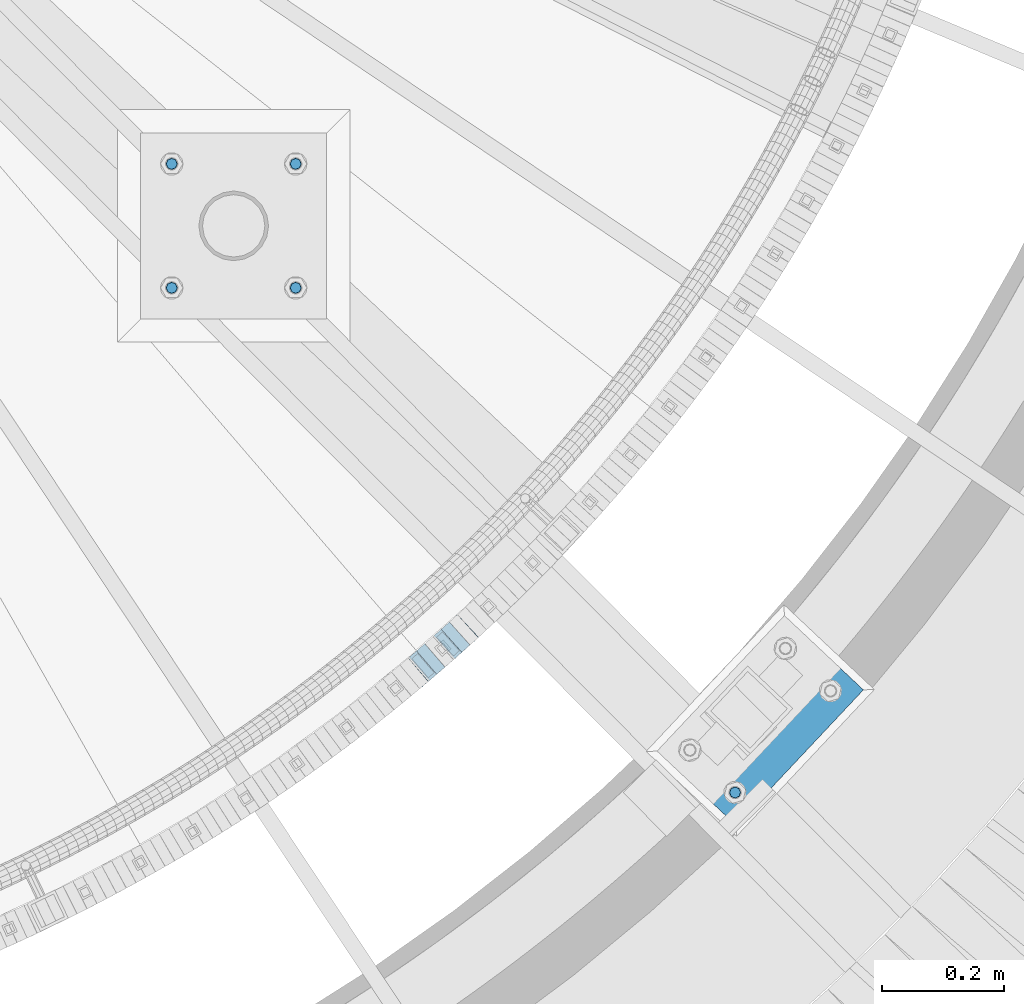
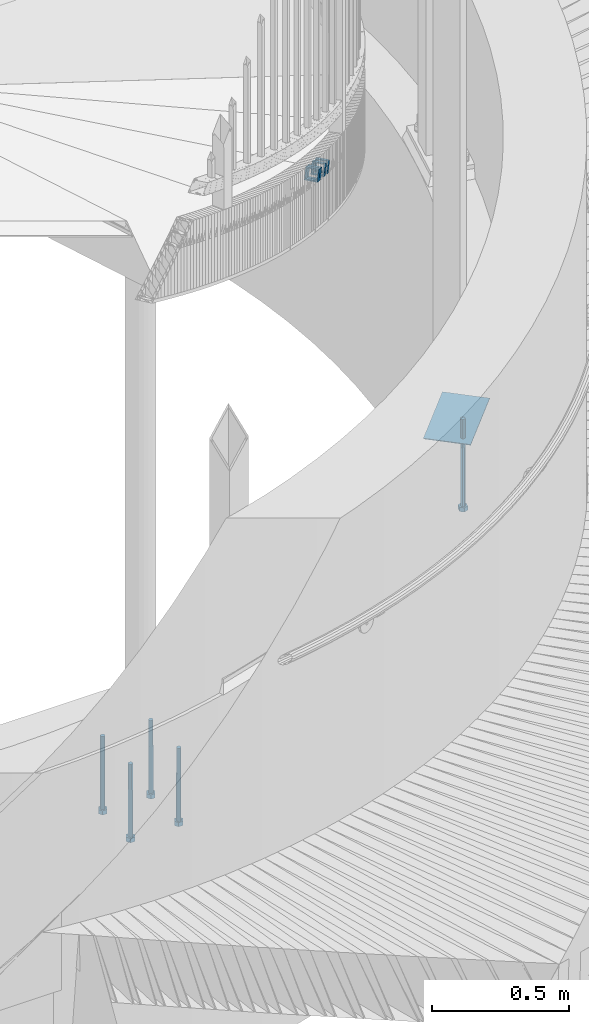
# One storey, part 491 of 975: 10 beams.
"""IFC2X3 building model written with IfcOpenShell, lengths in millimetres."""

from ifc_helpers import new_model, si_unit, frame, origin_with_axes, place, context, subcontext, project, spatial, faceted_brep, material, type_object, element, save


model = new_model("IFC2X3")

# Units and contexts
model_context = context("Model", 3, precision=1e-05, world=origin_with_axes())
body_context = subcontext(model_context, "Body", "Model", "MODEL_VIEW")
ifc_project = project(units=[si_unit("LENGTHUNIT", "METRE", prefix="MILLI"), si_unit("AREAUNIT", "SQUARE_METRE"), si_unit("VOLUMEUNIT", "CUBIC_METRE"), si_unit("MASSUNIT", "GRAM", prefix="KILO"), si_unit("TIMEUNIT", "SECOND"), si_unit("PLANEANGLEUNIT", "RADIAN"), si_unit("SOLIDANGLEUNIT", "STERADIAN"), si_unit("THERMODYNAMICTEMPERATUREUNIT", "DEGREE_CELSIUS"), si_unit("LUMINOUSINTENSITYUNIT", "LUMEN")], contexts=[model_context])

# Site, building, storey
site_placement = place(None, origin_with_axes())
site = spatial("IfcSite", under=ifc_project, at=site_placement, CompositionType="ELEMENT")
building_placement = place(site_placement, origin_with_axes())
building = spatial("IfcBuilding", under=site, at=building_placement, Name="Undefined", CompositionType="ELEMENT")
storey_placement = place(building_placement, origin_with_axes())
storey = spatial("IfcBuildingStorey", under=building, at=storey_placement, Name="Undefined", CompositionType="ELEMENT", Elevation=0.0)

# Beams
ifc_material_1 = material()
beam_type_1 = type_object("IfcBeamType", Name="HSS2X2X.188_TUBES", PredefinedType="NOTDEFINED")
for number, where, z_axis, x_axis, name in (
    (1, (36586.3070314841, 1210.1230873625, 2648.6316623909), (-0.652167428575804, 0.758074960082988, -1.21461653179722e-10), (0.721315416246313, 0.620543409211908, -0.307619810105057), "WALL"),
    (2, (36599.9070314841, 1221.82308736249, 2642.8316623909), (-0.652167428575804, 0.758074960082988, -1.21461653179722e-10), (0.721315416246313, 0.620543409211908, -0.307619810105057), "WALL"),
):
    element("IfcBeam", number, at=place(storey_placement, frame(where, z_axis=z_axis, x_axis=x_axis)), inside=storey, type_object=beam_type_1, material=ifc_material_1, Name=name, ObjectType="HSS2X2X.188_TUBES", context=body_context, shape_type="Brep", body=[
        faceted_brep([(0.0, 20.6374999999753, -20.6375000000298), (0.0, -20.6375000000153, -20.6375000000153), (18.8480768248774, -20.6374999999716, -20.6375000000735), (18.8480768249356, 20.6375000000153, -20.6375000000226), (0.0, -20.6374999999825, 20.6375000000335), (18.8480768249283, -20.6374999999935, 20.6374999999716), (0.0, 20.6375000000116, 20.6375000000189), (18.8480768249865, 20.6374999999935, 20.6375000000262), (0.0, 25.3999999999724, -25.4000000000342), (0.0, 25.400000000016, 25.4000000000196), (18.848076825001, 25.3999999999887, 25.4000000000378), (18.8480768249392, 25.4000000000142, -25.4000000000233), (0.0, -25.399999999976, 25.4000000000378), (18.8480768249283, -25.399999999996, 25.3999999999833), (0.0, -25.400000000016, -25.4000000000196), (18.8480768248664, -25.3999999999687, -25.4000000000779)], [[[0, 1, 2, 3]], [[1, 4, 5, 2]], [[4, 6, 7, 5]], [[6, 0, 3, 7]], [[8, 9, 10, 11]], [[9, 12, 13, 10]], [[12, 14, 15, 13]], [[14, 8, 11, 15]], [[13, 15, 11, 10], [5, 7, 3, 2]], [[14, 12, 9, 8], [6, 4, 1, 0]]]),
    ])
beam_1_placement = place(storey_placement, frame((36640.8512122932, 1257.4100463893, 2625.64368106898), z_axis=(-0.666794859366766, 0.74524131361731, 1.71758983924519e-10), x_axis=(0.708751451080152, 0.634146035071732, -0.309079580034951)))
element("IfcBeam", 3, at=beam_1_placement, inside=storey, type_object=beam_type_1, material=ifc_material_1, Name="WALL", ObjectType="HSS2X2X.188_TUBES", context=body_context, shape_type="Brep", body=[
    faceted_brep([(0.0, 20.6374999999753, -20.6375000000298), (0.0, -20.6375000000153, -20.6375000000153), (18.767258723612, -20.6375000000025, -20.6374999999862), (18.7672587236229, 20.6374999999953, -20.637499999968), (0.0, -20.6374999999825, 20.6375000000335), (18.767258723612, -20.6375000000135, 20.6375000000153), (0.0, 20.6375000000116, 20.6375000000189), (18.7672587236266, 20.6374999999844, 20.6375000000371), (0.0, 25.3999999999724, -25.4000000000342), (0.0, 25.400000000016, 25.4000000000196), (18.7672587236302, 25.3999999999814, 25.4000000000342), (18.7672587236229, 25.399999999996, -25.3999999999687), (0.0, -25.399999999976, 25.4000000000378), (18.7672587236157, -25.4000000000142, 25.400000000016), (0.0, -25.400000000016, -25.4000000000196), (18.767258723612, -25.4000000000015, -25.3999999999905)], [[[0, 1, 2, 3]], [[1, 4, 5, 2]], [[4, 6, 7, 5]], [[6, 0, 3, 7]], [[8, 9, 10, 11]], [[9, 12, 13, 10]], [[12, 14, 15, 13]], [[14, 8, 11, 15]], [[13, 15, 11, 10], [5, 7, 3, 2]], [[14, 12, 9, 8], [6, 4, 1, 0]]]),
])
beam_2_placement = place(storey_placement, frame((36667.8285496277, 1281.58500124165, 2614.14542239957), z_axis=(-0.678512970064767, 0.734588421807674, 5.79152583668474e-11), x_axis=(0.698569804897863, 0.645243865905667, -0.309290447954784)))
element("IfcBeam", 4, at=beam_2_placement, inside=storey, type_object=beam_type_1, material=ifc_material_1, Name="WALL", ObjectType="HSS2X2X.188_TUBES", context=body_context, shape_type="Brep", body=[
    faceted_brep([(0.0, 20.6374999999753, -20.6375000000298), (0.0, -20.6375000000153, -20.6375000000153), (18.7547327359644, -20.6374999999844, -20.6375000000553), (18.7547327359898, 20.6375000000171, -20.6375000000335), (0.0, -20.6374999999825, 20.6375000000335), (18.7547327360044, -20.6374999999953, 20.6374999999898), (0.0, 20.6375000000116, 20.6375000000189), (18.7547327360262, 20.6375000000062, 20.6375000000116), (0.0, 25.3999999999724, -25.4000000000342), (0.0, 25.400000000016, 25.4000000000196), (18.7547327360371, 25.4000000000033, 25.4000000000124), (18.7547327359898, 25.4000000000178, -25.4000000000342), (0.0, -25.399999999976, 25.4000000000378), (18.7547327360044, -25.399999999996, 25.3999999999869), (0.0, -25.400000000016, -25.4000000000196), (18.7547327359498, -25.3999999999814, -25.4000000000597)], [[[0, 1, 2, 3]], [[1, 4, 5, 2]], [[4, 6, 7, 5]], [[6, 0, 3, 7]], [[8, 9, 10, 11]], [[9, 12, 13, 10]], [[12, 14, 15, 13]], [[14, 8, 11, 15]], [[13, 15, 11, 10], [5, 7, 3, 2]], [[14, 12, 9, 8], [6, 4, 1, 0]]]),
])
ifc_material_2 = material(Name="STEEL/F1554-36")
beam_type_2 = type_object("IfcBeamType", PredefinedType="NOTDEFINED")
beam_3_placement = place(storey_placement, frame((37111.455464401, 1013.89217511915, 1371.6), z_axis=(0.684674324933948, 0.728849139929686, 0.0), x_axis=(0.0, 0.0, -1.0)))
element("IfcBeam", 5, at=beam_3_placement, inside=storey, type_object=beam_type_2, material=ifc_material_2, Name="HEADED_ANCHOR_BOLT", context=body_context, shape_type="Brep", body=[
    faceted_brep([(260.34375, -9.13000011445183, 15.8100004195221), (260.34375, -18.2600002289691, -1.45519152283669e-11), (279.393749999999, -18.2600002289691, -1.45519152283669e-11), (279.393749999999, -9.13000011445183, 15.8100004195221), (260.34375, 9.13000011451732, 15.8100004195403), (279.393749999999, 9.13000011451732, 15.8100004195403), (260.34375, 18.2600002289728, 1.81898940354586e-11), (279.393749999999, 18.2600002289728, 1.81898940354586e-11), (260.34375, 9.13000011445547, -15.8100004195221), (279.393749999999, 9.13000011445547, -15.8100004195221), (260.34375, -9.13000011451732, -15.8100004195367), (279.393749999999, -9.13000011451732, -15.8100004195367), (260.34375, -4.47768005528269, 9.29799844174704), (260.34375, -8.06850066050174, 6.43441456486471), (260.34375, -10.0612557562381, 2.29641597050068), (260.34375, -10.0612557562454, -2.29641597051523), (260.34375, -8.06850066052721, -6.43441456487926), (260.34375, -4.47768005531907, -9.29799844175068), (260.34375, -1.81898940354586e-11, -10.319999694766), (260.34375, 4.47768005528633, -9.2979984417434), (260.34375, 8.06850066050174, -6.43441456486471), (260.34375, 10.0612557562381, -2.29641597050068), (260.34375, 10.0612557562454, 2.29641597051886), (260.34375, 8.06850066052357, 6.4344145648829), (260.34375, 4.47768005532271, 9.29799844175432), (260.34375, 2.18278728425503e-11, 10.3199996947696), (279.393749999999, 2.18278728425503e-11, 10.3199996947696), (279.393749999999, -4.47768005528269, 9.29799844174704), (279.393749999999, -8.06850066050174, 6.43441456486471), (279.393749999999, -10.0612557562381, 2.29641597050068), (279.393749999999, -10.0612557562454, -2.29641597051523), (279.393749999999, -8.06850066052721, -6.43441456487926), (279.393749999999, -4.47768005531907, -9.29799844175068), (279.393749999999, -1.81898940354586e-11, -10.319999694766), (279.393749999999, 4.47768005528633, -9.2979984417434), (279.393749999999, 8.06850066050174, -6.43441456486471), (279.393749999999, 10.0612557562381, -2.29641597050068), (279.393749999999, 10.0612557562454, 2.29641597051886), (279.393749999999, 8.06850066052357, 6.4344145648829), (279.393749999999, 4.47768005532271, 9.29799844175432), (0.0, -6.73519209080223, 6.73519209080186), (0.0, -9.52499999999964, 0.0), (279.400000000001, -9.52499999999782, -3.63797880709171e-12), (279.400000000001, -6.73519209079313, 6.73519209079313), (-9.87109982941227e-13, -1.20792265079217e-13, 9.52499961853027), (279.400000000001, 1.09139364212751e-11, 9.52499999999054), (0.0, 6.73519209080223, 6.73519209080186), (279.400000000001, 6.73519209081132, 6.73519209079677), (0.0, 9.52499999999964, 0.0), (279.400000000001, 9.52500000000146, 3.63797880709171e-12), (0.0, 6.73519209080223, -6.73519209080186), (279.400000000001, 6.73519209079677, -6.73519209079313), (2.95075507493764e-12, -1.20792265079217e-13, -9.52499961853027), (279.400000000001, -1.09139364212751e-11, -9.5249999999869), (-126.99791499542, -6.36396103070001, 6.3639610306418), (-126.99791499542, 1.81898940354586e-11, 8.99999999995271), (-126.99791499542, 6.36396103072184, 6.36396103065272), (-126.99791499542, 9.00000000004366, 1.09139364212751e-11), (-126.99791499542, 6.36396103069637, -6.3639610306418), (-126.99791499542, -1.81898940354586e-11, -8.99999999995271), (-126.99791499542, -6.36396103072184, -6.36396103064908), (-126.99791499542, -9.00000000004002, -7.27595761418343e-12), (0.0149743263646087, 6.36396103067818, -6.36396103067909), (0.0149743263646087, 0.0, -9.0), (0.0149743263646087, -6.36396103067818, -6.36396103067909), (0.0149743263987148, -8.9999995411581, -1.00796984270346e-06), (0.0149743263646087, -6.36396103067818, 6.36396103067909), (0.0149743263646087, 0.0, 9.0), (0.0149743263646087, 6.36396103067818, 6.36396103067909), (0.0149743263987148, 9.0000004588419, -1.00796984270346e-06), (0.0, -6.73519209080223, -6.73519209080186), (279.400000000001, -6.73519209080769, -6.73519209079677)], [[[0, 1, 2, 3]], [[4, 0, 3, 5]], [[6, 4, 5, 7]], [[8, 6, 7, 9]], [[10, 8, 9, 11]], [[0, 4, 6, 8, 10, 1], [12, 13, 14, 15, 16, 17, 18, 19, 20, 21, 22, 23, 24, 25]], [[12, 25, 26, 27]], [[13, 12, 27, 28]], [[14, 13, 28, 29]], [[15, 14, 29, 30]], [[16, 15, 30, 31]], [[17, 16, 31, 32]], [[18, 17, 32, 33]], [[19, 18, 33, 34]], [[20, 19, 34, 35]], [[21, 20, 35, 36]], [[22, 21, 36, 37]], [[23, 22, 37, 38]], [[24, 23, 38, 39]], [[25, 24, 39, 26]], [[9, 7, 5, 3, 2, 11], [38, 37, 36, 35, 34, 33, 32, 31, 30, 29, 28, 27, 26, 39]], [[1, 10, 11, 2]], [[40, 41, 42, 43]], [[44, 40, 43, 45]], [[46, 44, 45, 47]], [[48, 46, 47, 49]], [[50, 48, 49, 51]], [[52, 50, 51, 53]], [[54, 55, 56, 57, 58, 59, 60, 61]], [[59, 58, 62, 63]], [[60, 59, 63, 64]], [[61, 60, 64, 65]], [[54, 61, 65, 66]], [[55, 54, 66, 67]], [[56, 55, 67, 68]], [[57, 56, 68, 69]], [[58, 57, 69, 62]], [[40, 44, 46, 48, 50, 52, 70, 41], [68, 67, 66, 65, 64, 63, 62, 69]], [[41, 70, 71, 42]], [[53, 51, 49, 47, 45, 43, 42, 71]], [[70, 52, 53, 71]]]),
])
beam_4_placement = place(storey_placement, frame((36391.217401814, 1841.14041171236, -330.199999999999), z_axis=(0.0, 1.0, 0.0), x_axis=(0.0, 0.0, -1.0)))
element("IfcBeam", 6, at=beam_4_placement, inside=storey, type_object=beam_type_2, material=ifc_material_2, Name="HEADED_ANCHOR_BOLT", context=body_context, shape_type="Brep", body=[
    faceted_brep([(209.543749999999, -9.13000011446275, 15.8100004196049), (209.543749999999, -18.2600002288382, 4.72937244921923e-11), (228.593749999998, -18.2600002288382, 4.72937244921923e-11), (228.593749999998, -9.13000011446275, 15.8100004196049), (209.543749999999, 9.13000011438271, 15.8100004195576), (228.593749999998, 9.13000011438271, 15.8100004195576), (209.543749999999, 18.2600002288382, -4.72937244921923e-11), (228.593749999998, 18.2600002288382, -4.72937244921923e-11), (209.543749999999, 9.13000011446275, -15.8100004196049), (228.593749999998, 9.13000011446275, -15.8100004196049), (209.543749999999, -9.13000011438271, -15.8100004195576), (228.593749999998, -9.13000011438271, -15.8100004195576), (209.543749999999, -4.4776800552936, 9.29799844178979), (209.543749999999, -8.068500660469, 6.43441456491473), (209.543749999999, -10.0612557561763, 2.2964159705416), (209.543749999999, -10.0612557561617, -2.29641597048976), (209.543749999999, -8.0685006604399, -6.4344145648729), (209.543749999999, -4.47768005524995, -9.29799844176705), (209.543749999999, 2.91038304567337e-11, -10.3199996948015), (209.543749999999, 4.4776800552936, -9.29799844178979), (209.543749999999, 8.068500660469, -6.43441456491473), (209.543749999999, 10.0612557561763, -2.2964159705416), (209.543749999999, 10.0612557561617, 2.29641597048976), (209.543749999999, 8.0685006604399, 6.4344145648729), (209.543749999999, 4.47768005524995, 9.29799844176705), (209.543749999999, -2.91038304567337e-11, 10.3199996948015), (228.593749999998, -2.91038304567337e-11, 10.3199996948015), (228.593749999998, -4.4776800552936, 9.29799844178979), (228.593749999998, -8.068500660469, 6.43441456491473), (228.593749999998, -10.0612557561763, 2.2964159705416), (228.593749999998, -10.0612557561617, -2.29641597048976), (228.593749999998, -8.0685006604399, -6.4344145648729), (228.593749999998, -4.47768005524995, -9.29799844176705), (228.593749999998, 2.91038304567337e-11, -10.3199996948015), (228.593749999998, 4.4776800552936, -9.29799844178979), (228.593749999998, 8.068500660469, -6.43441456491473), (228.593749999998, 10.0612557561763, -2.2964159705416), (228.593749999998, 10.0612557561617, 2.29641597048976), (228.593749999998, 8.0685006604399, 6.4344145648729), (228.593749999998, 4.47768005524995, 9.29799844176705), (0.0, -6.73519209080223, 6.73519209080186), (0.0, -9.52499999999964, 0.0), (228.6, -9.52500000000146, 0.0), (228.6, -6.73519209080405, 6.73519209080223), (-9.87109982941227e-13, -1.20792265079217e-13, 9.52499961853027), (228.6, 0.0, 9.52499999999964), (0.0, 6.73519209080223, 6.73519209080186), (228.6, 6.73519209080405, 6.73519209080223), (0.0, 9.52499999999964, 0.0), (228.6, 9.52500000000146, 0.0), (0.0, 6.73519209080223, -6.73519209080186), (228.6, 6.73519209080405, -6.73519209080223), (2.95075507493764e-12, -1.20792265079217e-13, -9.52499961853027), (228.6, 0.0, -9.52499999999964), (-114.297914995421, -6.36396103067818, 6.36396103068091), (-114.297914995421, -2.18278728425503e-11, 8.99999999997999), (-114.297914995421, 6.36396103064908, 6.36396103064817), (-114.297914995421, 8.99999999997817, -2.27373675443232e-11), (-114.297914995421, 6.36396103067818, -6.36396103068091), (-114.297914995421, 2.18278728425503e-11, -8.99999999997999), (-114.297914995421, -6.36396103064908, -6.36396103064817), (-114.297914995421, -8.99999999997817, 2.27373675443232e-11), (0.0149743263646087, 6.36396103067818, -6.36396103067909), (0.0149743263646087, 0.0, -9.0), (0.0149743263646087, -6.36396103067818, -6.36396103067909), (0.0149743263987148, -8.9999995411581, -1.00796984270346e-06), (0.0149743263646087, -6.36396103067818, 6.36396103067909), (0.0149743263646087, 0.0, 9.0), (0.0149743263646087, 6.36396103067818, 6.36396103067909), (0.0149743263987148, 9.0000004588419, -1.00796984270346e-06), (0.0, -6.73519209080223, -6.73519209080186), (228.6, -6.73519209080405, -6.73519209080223)], [[[0, 1, 2, 3]], [[4, 0, 3, 5]], [[6, 4, 5, 7]], [[8, 6, 7, 9]], [[10, 8, 9, 11]], [[0, 4, 6, 8, 10, 1], [12, 13, 14, 15, 16, 17, 18, 19, 20, 21, 22, 23, 24, 25]], [[12, 25, 26, 27]], [[13, 12, 27, 28]], [[14, 13, 28, 29]], [[15, 14, 29, 30]], [[16, 15, 30, 31]], [[17, 16, 31, 32]], [[18, 17, 32, 33]], [[19, 18, 33, 34]], [[20, 19, 34, 35]], [[21, 20, 35, 36]], [[22, 21, 36, 37]], [[23, 22, 37, 38]], [[24, 23, 38, 39]], [[25, 24, 39, 26]], [[9, 7, 5, 3, 2, 11], [38, 37, 36, 35, 34, 33, 32, 31, 30, 29, 28, 27, 26, 39]], [[1, 10, 11, 2]], [[40, 41, 42, 43]], [[44, 40, 43, 45]], [[46, 44, 45, 47]], [[48, 46, 47, 49]], [[50, 48, 49, 51]], [[52, 50, 51, 53]], [[54, 55, 56, 57, 58, 59, 60, 61]], [[59, 58, 62, 63]], [[60, 59, 63, 64]], [[61, 60, 64, 65]], [[54, 61, 65, 66]], [[55, 54, 66, 67]], [[56, 55, 67, 68]], [[57, 56, 68, 69]], [[58, 57, 69, 62]], [[40, 44, 46, 48, 50, 52, 70, 41], [68, 67, 66, 65, 64, 63, 62, 69]], [[41, 70, 71, 42]], [[53, 51, 49, 47, 45, 43, 42, 71]], [[70, 52, 53, 71]]]),
])
beam_5_placement = place(storey_placement, frame((36188.0174048657, 1841.14041171236, -330.199999999999), z_axis=(0.0, 1.0, 0.0), x_axis=(0.0, 0.0, -1.0)))
element("IfcBeam", 7, at=beam_5_placement, inside=storey, type_object=beam_type_2, material=ifc_material_2, Name="HEADED_ANCHOR_BOLT", context=body_context, shape_type="Brep", body=[
    faceted_brep([(209.543749999999, 9.13000011446275, -15.8100004196049), (209.543749999999, 18.2600002288382, -4.72937244921923e-11), (228.593749999998, 18.2600002288382, -4.72937244921923e-11), (228.593749999998, 9.13000011446275, -15.8100004196049), (209.543749999999, -9.13000011438271, -15.8100004195576), (228.593749999998, -9.13000011438271, -15.8100004195576), (209.543749999999, -18.2600002288382, 4.72937244921923e-11), (228.593749999998, -18.2600002288382, 4.72937244921923e-11), (209.543749999999, -9.13000011446275, 15.8100004196049), (228.593749999998, -9.13000011446275, 15.8100004196049), (209.543749999999, 9.13000011438271, 15.8100004195576), (228.593749999998, 9.13000011438271, 15.8100004195576), (209.543749999999, -4.4776800552936, 9.29799844178979), (209.543749999999, -8.068500660469, 6.43441456491473), (209.543749999999, -10.0612557561763, 2.2964159705416), (209.543749999999, -10.0612557561617, -2.29641597048976), (209.543749999999, -8.0685006604399, -6.4344145648729), (209.543749999999, -4.47768005524995, -9.29799844176705), (209.543749999999, 2.91038304567337e-11, -10.3199996948015), (209.543749999999, 4.4776800552936, -9.29799844178979), (209.543749999999, 8.068500660469, -6.43441456491473), (209.543749999999, 10.0612557561763, -2.2964159705416), (209.543749999999, 10.0612557561617, 2.29641597048976), (209.543749999999, 8.0685006604399, 6.4344145648729), (209.543749999999, 4.47768005524995, 9.29799844176705), (209.543749999999, -2.91038304567337e-11, 10.3199996948015), (228.593749999998, 2.91038304567337e-11, -10.3199996948015), (228.593749999998, 4.4776800552936, -9.29799844178979), (228.593749999998, 8.068500660469, -6.43441456491473), (228.593749999998, 10.0612557561763, -2.2964159705416), (228.593749999998, 10.0612557561617, 2.29641597048976), (228.593749999998, 8.0685006604399, 6.4344145648729), (228.593749999998, 4.47768005524995, 9.29799844176705), (228.593749999998, -2.91038304567337e-11, 10.3199996948015), (228.593749999998, -4.4776800552936, 9.29799844178979), (228.593749999998, -8.068500660469, 6.43441456491473), (228.593749999998, -10.0612557561763, 2.2964159705416), (228.593749999998, -10.0612557561617, -2.29641597048976), (228.593749999998, -8.0685006604399, -6.4344145648729), (228.593749999998, -4.47768005524995, -9.29799844176705), (0.0, -6.73519209080223, 6.73519209080186), (0.0, -9.52499999999964, 0.0), (228.6, -9.52500000000146, 0.0), (228.6, -6.73519209080405, 6.73519209080223), (-9.87109982941227e-13, -1.20792265079217e-13, 9.52499961853027), (228.6, 0.0, 9.52499999999964), (0.0, 6.73519209080223, 6.73519209080186), (228.6, 6.73519209080405, 6.73519209080223), (0.0, 9.52499999999964, 0.0), (228.6, 9.52500000000146, 0.0), (0.0, 6.73519209080223, -6.73519209080186), (228.6, 6.73519209080405, -6.73519209080223), (2.95075507493764e-12, -1.20792265079217e-13, -9.52499961853027), (228.6, 0.0, -9.52499999999964), (-114.297914995421, -6.36396103067818, 6.36396103068091), (-114.297914995421, -2.18278728425503e-11, 8.99999999997999), (-114.297914995421, 6.36396103064908, 6.36396103064817), (-114.297914995421, 8.99999999997817, -2.27373675443232e-11), (-114.297914995421, 6.36396103067818, -6.36396103068091), (-114.297914995421, 2.18278728425503e-11, -8.99999999997999), (-114.297914995421, -6.36396103064908, -6.36396103064817), (-114.297914995421, -8.99999999997817, 2.27373675443232e-11), (0.0149743263646087, 6.36396103067818, -6.36396103067909), (0.0149743263646087, 0.0, -9.0), (0.0149743263646087, -6.36396103067818, -6.36396103067909), (0.0149743263987148, -8.9999995411581, -1.00796984270346e-06), (0.0149743263646087, -6.36396103067818, 6.36396103067909), (0.0149743263646087, 0.0, 9.0), (0.0149743263646087, 6.36396103067818, 6.36396103067909), (0.0149743263987148, 9.0000004588419, -1.00796984270346e-06), (0.0, -6.73519209080223, -6.73519209080186), (228.6, -6.73519209080405, -6.73519209080223)], [[[0, 1, 2, 3]], [[4, 0, 3, 5]], [[6, 4, 5, 7]], [[8, 6, 7, 9]], [[10, 8, 9, 11]], [[8, 10, 1, 0, 4, 6], [12, 13, 14, 15, 16, 17, 18, 19, 20, 21, 22, 23, 24, 25]], [[19, 18, 26, 27]], [[20, 19, 27, 28]], [[21, 20, 28, 29]], [[22, 21, 29, 30]], [[23, 22, 30, 31]], [[24, 23, 31, 32]], [[25, 24, 32, 33]], [[12, 25, 33, 34]], [[13, 12, 34, 35]], [[14, 13, 35, 36]], [[15, 14, 36, 37]], [[16, 15, 37, 38]], [[17, 16, 38, 39]], [[18, 17, 39, 26]], [[3, 2, 11, 9, 7, 5], [31, 30, 29, 28, 27, 26, 39, 38, 37, 36, 35, 34, 33, 32]], [[1, 10, 11, 2]], [[40, 41, 42, 43]], [[44, 40, 43, 45]], [[46, 44, 45, 47]], [[48, 46, 47, 49]], [[50, 48, 49, 51]], [[52, 50, 51, 53]], [[54, 55, 56, 57, 58, 59, 60, 61]], [[59, 58, 62, 63]], [[60, 59, 63, 64]], [[61, 60, 64, 65]], [[54, 61, 65, 66]], [[55, 54, 66, 67]], [[56, 55, 67, 68]], [[57, 56, 68, 69]], [[58, 57, 69, 62]], [[40, 44, 46, 48, 50, 52, 70, 41], [68, 67, 66, 65, 64, 63, 62, 69]], [[41, 70, 71, 42]], [[53, 51, 49, 47, 45, 43, 42, 71]], [[70, 52, 53, 71]]]),
])
beam_6_placement = place(storey_placement, frame((36188.0174048657, 2044.3404086606, -330.199999999999), z_axis=(0.0, 1.0, 0.0), x_axis=(0.0, 0.0, -1.0)))
element("IfcBeam", 8, at=beam_6_placement, inside=storey, type_object=beam_type_2, material=ifc_material_2, Name="HEADED_ANCHOR_BOLT", context=body_context, shape_type="Brep", body=[
    faceted_brep([(209.543749999999, 9.13000011446275, -15.8100004196049), (209.543749999999, 18.2600002288382, -4.72937244921923e-11), (228.593749999998, 18.2600002288382, -4.72937244921923e-11), (228.593749999998, 9.13000011446275, -15.8100004196049), (209.543749999999, -9.13000011438271, -15.8100004195576), (228.593749999998, -9.13000011438271, -15.8100004195576), (209.543749999999, -18.2600002288382, 4.72937244921923e-11), (228.593749999998, -18.2600002288382, 4.72937244921923e-11), (209.543749999999, -9.13000011446275, 15.8100004196049), (228.593749999998, -9.13000011446275, 15.8100004196049), (209.543749999999, 9.13000011438271, 15.8100004195576), (228.593749999998, 9.13000011438271, 15.8100004195576), (209.543749999999, -4.4776800552936, 9.29799844178979), (209.543749999999, -8.068500660469, 6.43441456491473), (209.543749999999, -10.0612557561763, 2.2964159705416), (209.543749999999, -10.0612557561617, -2.29641597048976), (209.543749999999, -8.0685006604399, -6.4344145648729), (209.543749999999, -4.47768005524995, -9.29799844176705), (209.543749999999, 2.91038304567337e-11, -10.3199996948015), (209.543749999999, 4.4776800552936, -9.29799844178979), (209.543749999999, 8.068500660469, -6.43441456491473), (209.543749999999, 10.0612557561763, -2.2964159705416), (209.543749999999, 10.0612557561617, 2.29641597048976), (209.543749999999, 8.0685006604399, 6.4344145648729), (209.543749999999, 4.47768005524995, 9.29799844176705), (209.543749999999, -2.91038304567337e-11, 10.3199996948015), (228.593749999998, 2.91038304567337e-11, -10.3199996948015), (228.593749999998, 4.4776800552936, -9.29799844178979), (228.593749999998, 8.068500660469, -6.43441456491473), (228.593749999998, 10.0612557561763, -2.2964159705416), (228.593749999998, 10.0612557561617, 2.29641597048976), (228.593749999998, 8.0685006604399, 6.4344145648729), (228.593749999998, 4.47768005524995, 9.29799844176705), (228.593749999998, -2.91038304567337e-11, 10.3199996948015), (228.593749999998, -4.4776800552936, 9.29799844178979), (228.593749999998, -8.068500660469, 6.43441456491473), (228.593749999998, -10.0612557561763, 2.2964159705416), (228.593749999998, -10.0612557561617, -2.29641597048976), (228.593749999998, -8.0685006604399, -6.4344145648729), (228.593749999998, -4.47768005524995, -9.29799844176705), (0.0, -6.73519209080223, 6.73519209080186), (0.0, -9.52499999999964, 0.0), (228.6, -9.52500000000146, 0.0), (228.6, -6.73519209080405, 6.73519209080223), (-9.87109982941227e-13, -1.20792265079217e-13, 9.52499961853027), (228.6, 0.0, 9.52499999999964), (0.0, 6.73519209080223, 6.73519209080186), (228.6, 6.73519209080405, 6.73519209080223), (0.0, 9.52499999999964, 0.0), (228.6, 9.52500000000146, 0.0), (0.0, 6.73519209080223, -6.73519209080186), (228.6, 6.73519209080405, -6.73519209080223), (2.95075507493764e-12, -1.20792265079217e-13, -9.52499961853027), (228.6, 0.0, -9.52499999999964), (-114.297914995421, -6.36396103067818, 6.36396103068091), (-114.297914995421, -2.18278728425503e-11, 8.99999999997999), (-114.297914995421, 6.36396103064908, 6.36396103064817), (-114.297914995421, 8.99999999997817, -2.27373675443232e-11), (-114.297914995421, 6.36396103067818, -6.36396103068091), (-114.297914995421, 2.18278728425503e-11, -8.99999999997999), (-114.297914995421, -6.36396103064908, -6.36396103064817), (-114.297914995421, -8.99999999997817, 2.27373675443232e-11), (0.0149743263646087, 6.36396103067818, -6.36396103067909), (0.0149743263646087, 0.0, -9.0), (0.0149743263646087, -6.36396103067818, -6.36396103067909), (0.0149743263987148, -8.9999995411581, -1.00796984270346e-06), (0.0149743263646087, -6.36396103067818, 6.36396103067909), (0.0149743263646087, 0.0, 9.0), (0.0149743263646087, 6.36396103067818, 6.36396103067909), (0.0149743263987148, 9.0000004588419, -1.00796984270346e-06), (0.0, -6.73519209080223, -6.73519209080186), (228.6, -6.73519209080405, -6.73519209080223)], [[[0, 1, 2, 3]], [[4, 0, 3, 5]], [[6, 4, 5, 7]], [[8, 6, 7, 9]], [[10, 8, 9, 11]], [[8, 10, 1, 0, 4, 6], [12, 13, 14, 15, 16, 17, 18, 19, 20, 21, 22, 23, 24, 25]], [[19, 18, 26, 27]], [[20, 19, 27, 28]], [[21, 20, 28, 29]], [[22, 21, 29, 30]], [[23, 22, 30, 31]], [[24, 23, 31, 32]], [[25, 24, 32, 33]], [[12, 25, 33, 34]], [[13, 12, 34, 35]], [[14, 13, 35, 36]], [[15, 14, 36, 37]], [[16, 15, 37, 38]], [[17, 16, 38, 39]], [[18, 17, 39, 26]], [[3, 2, 11, 9, 7, 5], [31, 30, 29, 28, 27, 26, 39, 38, 37, 36, 35, 34, 33, 32]], [[1, 10, 11, 2]], [[40, 41, 42, 43]], [[44, 40, 43, 45]], [[46, 44, 45, 47]], [[48, 46, 47, 49]], [[50, 48, 49, 51]], [[52, 50, 51, 53]], [[54, 55, 56, 57, 58, 59, 60, 61]], [[59, 58, 62, 63]], [[60, 59, 63, 64]], [[61, 60, 64, 65]], [[54, 61, 65, 66]], [[55, 54, 66, 67]], [[56, 55, 67, 68]], [[57, 56, 68, 69]], [[58, 57, 69, 62]], [[40, 44, 46, 48, 50, 52, 70, 41], [68, 67, 66, 65, 64, 63, 62, 69]], [[41, 70, 71, 42]], [[53, 51, 49, 47, 45, 43, 42, 71]], [[70, 52, 53, 71]]]),
])
beam_7_placement = place(storey_placement, frame((36391.217401814, 2044.3404086606, -330.199999999999), z_axis=(0.0, 1.0, 0.0), x_axis=(0.0, 0.0, -1.0)))
element("IfcBeam", 9, at=beam_7_placement, inside=storey, type_object=beam_type_2, material=ifc_material_2, Name="HEADED_ANCHOR_BOLT", context=body_context, shape_type="Brep", body=[
    faceted_brep([(209.543749999999, -9.13000011446275, 15.8100004196049), (209.543749999999, -18.2600002288382, 4.72937244921923e-11), (228.593749999998, -18.2600002288382, 4.72937244921923e-11), (228.593749999998, -9.13000011446275, 15.8100004196049), (209.543749999999, 9.13000011438271, 15.8100004195576), (228.593749999998, 9.13000011438271, 15.8100004195576), (209.543749999999, 18.2600002288382, -4.72937244921923e-11), (228.593749999998, 18.2600002288382, -4.72937244921923e-11), (209.543749999999, 9.13000011446275, -15.8100004196049), (228.593749999998, 9.13000011446275, -15.8100004196049), (209.543749999999, -9.13000011438271, -15.8100004195576), (228.593749999998, -9.13000011438271, -15.8100004195576), (209.543749999999, -4.4776800552936, 9.29799844178979), (209.543749999999, -8.068500660469, 6.43441456491473), (209.543749999999, -10.0612557561763, 2.2964159705416), (209.543749999999, -10.0612557561617, -2.29641597048976), (209.543749999999, -8.0685006604399, -6.4344145648729), (209.543749999999, -4.47768005524995, -9.29799844176705), (209.543749999999, 2.91038304567337e-11, -10.3199996948015), (209.543749999999, 4.4776800552936, -9.29799844178979), (209.543749999999, 8.068500660469, -6.43441456491473), (209.543749999999, 10.0612557561763, -2.2964159705416), (209.543749999999, 10.0612557561617, 2.29641597048976), (209.543749999999, 8.0685006604399, 6.4344145648729), (209.543749999999, 4.47768005524995, 9.29799844176705), (209.543749999999, -2.91038304567337e-11, 10.3199996948015), (228.593749999998, -2.91038304567337e-11, 10.3199996948015), (228.593749999998, -4.4776800552936, 9.29799844178979), (228.593749999998, -8.068500660469, 6.43441456491473), (228.593749999998, -10.0612557561763, 2.2964159705416), (228.593749999998, -10.0612557561617, -2.29641597048976), (228.593749999998, -8.0685006604399, -6.4344145648729), (228.593749999998, -4.47768005524995, -9.29799844176705), (228.593749999998, 2.91038304567337e-11, -10.3199996948015), (228.593749999998, 4.4776800552936, -9.29799844178979), (228.593749999998, 8.068500660469, -6.43441456491473), (228.593749999998, 10.0612557561763, -2.2964159705416), (228.593749999998, 10.0612557561617, 2.29641597048976), (228.593749999998, 8.0685006604399, 6.4344145648729), (228.593749999998, 4.47768005524995, 9.29799844176705), (0.0, -6.73519209080223, 6.73519209080186), (0.0, -9.52499999999964, 0.0), (228.6, -9.52500000000146, 0.0), (228.6, -6.73519209080405, 6.73519209080223), (-9.87109982941227e-13, -1.20792265079217e-13, 9.52499961853027), (228.6, 0.0, 9.52499999999964), (0.0, 6.73519209080223, 6.73519209080186), (228.6, 6.73519209080405, 6.73519209080223), (0.0, 9.52499999999964, 0.0), (228.6, 9.52500000000146, 0.0), (0.0, 6.73519209080223, -6.73519209080186), (228.6, 6.73519209080405, -6.73519209080223), (2.95075507493764e-12, -1.20792265079217e-13, -9.52499961853027), (228.6, 0.0, -9.52499999999964), (-114.297914995421, -6.36396103067818, 6.36396103068091), (-114.297914995421, -2.18278728425503e-11, 8.99999999997999), (-114.297914995421, 6.36396103064908, 6.36396103064817), (-114.297914995421, 8.99999999997817, -2.27373675443232e-11), (-114.297914995421, 6.36396103067818, -6.36396103068091), (-114.297914995421, 2.18278728425503e-11, -8.99999999997999), (-114.297914995421, -6.36396103064908, -6.36396103064817), (-114.297914995421, -8.99999999997817, 2.27373675443232e-11), (0.0149743263646087, 6.36396103067818, -6.36396103067909), (0.0149743263646087, 0.0, -9.0), (0.0149743263646087, -6.36396103067818, -6.36396103067909), (0.0149743263987148, -8.9999995411581, -1.00796984270346e-06), (0.0149743263646087, -6.36396103067818, 6.36396103067909), (0.0149743263646087, 0.0, 9.0), (0.0149743263646087, 6.36396103067818, 6.36396103067909), (0.0149743263987148, 9.0000004588419, -1.00796984270346e-06), (0.0, -6.73519209080223, -6.73519209080186), (228.6, -6.73519209080405, -6.73519209080223)], [[[0, 1, 2, 3]], [[4, 0, 3, 5]], [[6, 4, 5, 7]], [[8, 6, 7, 9]], [[10, 8, 9, 11]], [[0, 4, 6, 8, 10, 1], [12, 13, 14, 15, 16, 17, 18, 19, 20, 21, 22, 23, 24, 25]], [[12, 25, 26, 27]], [[13, 12, 27, 28]], [[14, 13, 28, 29]], [[15, 14, 29, 30]], [[16, 15, 30, 31]], [[17, 16, 31, 32]], [[18, 17, 32, 33]], [[19, 18, 33, 34]], [[20, 19, 34, 35]], [[21, 20, 35, 36]], [[22, 21, 36, 37]], [[23, 22, 37, 38]], [[24, 23, 38, 39]], [[25, 24, 39, 26]], [[9, 7, 5, 3, 2, 11], [38, 37, 36, 35, 34, 33, 32, 31, 30, 29, 28, 27, 26, 39]], [[1, 10, 11, 2]], [[40, 41, 42, 43]], [[44, 40, 43, 45]], [[46, 44, 45, 47]], [[48, 46, 47, 49]], [[50, 48, 49, 51]], [[52, 50, 51, 53]], [[54, 55, 56, 57, 58, 59, 60, 61]], [[59, 58, 62, 63]], [[60, 59, 63, 64]], [[61, 60, 64, 65]], [[54, 61, 65, 66]], [[55, 54, 66, 67]], [[56, 55, 67, 68]], [[57, 56, 68, 69]], [[58, 57, 69, 62]], [[40, 44, 46, 48, 50, 52, 70, 41], [68, 67, 66, 65, 64, 63, 62, 69]], [[41, 70, 71, 42]], [[53, 51, 49, 47, 45, 43, 42, 71]], [[70, 52, 53, 71]]]),
])
ifc_material_3 = material(Name="STEEL/A36")
beam_type_3 = type_object("IfcBeamType", PredefinedType="NOTDEFINED")
beam_8_placement = place(storey_placement, frame((37257.0325705506, 1243.05769644381, 1411.2875), z_axis=(0.728849139929688, -0.684674324933946, 0.0), x_axis=(-0.684674324933948, -0.728849139929686, 0.0)))
element("IfcBeam", 10, at=beam_8_placement, inside=storey, type_object=beam_type_3, material=ifc_material_3, Name="TEMPLATE", context=body_context, shape_type="Brep", body=[
    faceted_brep([(-1.09139364212751e-11, 1.58750000000009, -88.900000000016), (3.63797880709171e-12, 1.58750000000009, 88.9000000000196), (304.800000000418, 1.58750000000009, 88.9000000003762), (304.800000000399, 1.58750000000009, -88.8999999996631), (3.63797880709171e-12, -1.58750000000009, 88.9000000000196), (304.800000000418, -1.58750000000009, 88.9000000003762), (-1.09139364212751e-11, -1.58750000000009, -88.900000000016), (304.800000000399, -1.58750000000009, -88.8999999996631)], [[[0, 1, 2, 3]], [[1, 4, 5, 2]], [[4, 6, 7, 5]], [[6, 0, 3, 7]], [[5, 7, 3, 2]], [[6, 4, 1, 0]]]),
])

save(model, "model.ifc")
